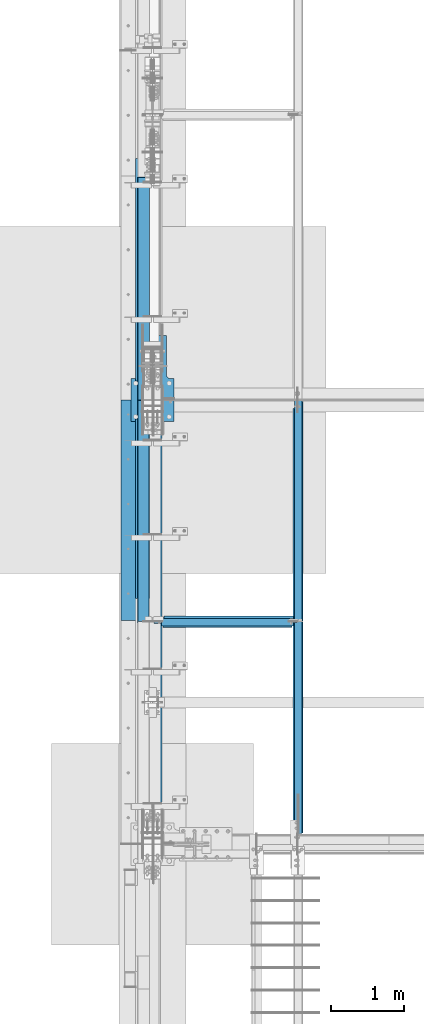
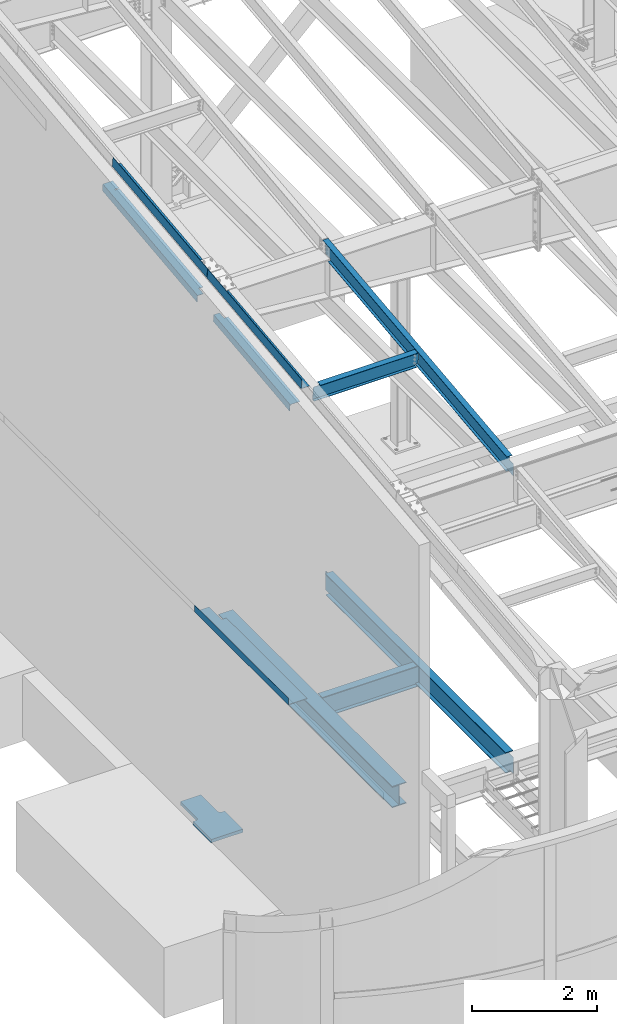
# One storey, part 707 of 1179: 11 beams, 8 elements without a shape of their own.
"""IFC2X3 building model written with IfcOpenShell, lengths in millimetres."""

import ifcopenshell
import ifcopenshell.guid

model = None  # the IFC model being written
_history = None  # IfcOwnerHistory: only IFC2X3 demands one
_inside = {}  # id of a spatial element -> (the spatial element, [elements in it])
_under = {}  # id of a project, library or spatial element -> (it, [spatial elements below it])
_declared = {}  # id of a project -> (the project, [libraries it declares])
_typed = {}  # id of a type object -> (the type object, [elements of that type])
_made_of = {}  # id of a material, layer set ... -> (it, [elements and type objects made of it])


def new_model(schema):
    """Start an empty IFC model of exactly this schema.

    Asked for "IFC4X3", IfcOpenShell would pick the latest addendum, in which some entities
    have other attributes; the version numbers below select the first issue.
    IFC2X3 requires an IfcOwnerHistory on every rooted entity: one is made here for all.
    """
    global model, _history
    if schema == "IFC4X3":
        model = ifcopenshell.file(schema_version=(4, 3, 0, 0))
    else:
        model = ifcopenshell.file(schema=schema)
    _inside.clear()
    _under.clear()
    _declared.clear()
    _typed.clear()
    _made_of.clear()
    _history = None
    if model.schema == "IFC2X3":
        org = make("IfcOrganization", Name="unknown")
        user = make(
            "IfcPersonAndOrganization",
            ThePerson=make("IfcPerson", FamilyName="unknown"),
            TheOrganization=org,
        )
        app = make(
            "IfcApplication",
            ApplicationDeveloper=org,
            Version="unknown",
            ApplicationFullName="unknown",
            ApplicationIdentifier="unknown",
        )
        _history = make(
            "IfcOwnerHistory",
            OwningUser=user,
            OwningApplication=app,
            ChangeAction="ADDED",
            CreationDate=0,
        )
    return model


def make(cls, **values):
    """One entity of the class cls with the attributes given. An attribute that is None is left unset."""
    return model.create_entity(
        cls, **{name: value for name, value in values.items() if value is not None}
    )


def rooted(cls, **values):
    """An entity with a GlobalId (a new one), such as an element, a storey or a relation."""
    return make(cls, GlobalId=ifcopenshell.guid.new(), OwnerHistory=_history, **values)


def si_unit(unit_type, name, prefix=None):
    """IfcSIUnit, for example si_unit("LENGTHUNIT", "METRE", prefix="MILLI")."""
    return make("IfcSIUnit", UnitType=unit_type, Prefix=prefix, Name=name)


def assignment(units):
    """IfcUnitAssignment: the units of a project."""
    return None if units is None else make("IfcUnitAssignment", Units=units)


def point(xyz):
    """IfcCartesianPoint."""
    return None if xyz is None else make("IfcCartesianPoint", Coordinates=xyz)


def direction(xyz):
    """IfcDirection."""
    return None if xyz is None else make("IfcDirection", DirectionRatios=xyz)


def frame(location, z_axis=None, x_axis=None):
    """IfcAxis2Placement3D, a coordinate frame: its origin and axes. An axis left out is left unset."""
    return make(
        "IfcAxis2Placement3D",
        Location=point(location),
        Axis=direction(z_axis),
        RefDirection=direction(x_axis),
    )


def origin_with_axes():
    """The frame at (0, 0, 0) with the z axis (0, 0, 1) and the x axis (1, 0, 0) written out."""
    return frame((0.0, 0.0, 0.0), z_axis=(0.0, 0.0, 1.0), x_axis=(1.0, 0.0, 0.0))


def place(relative_to, where):
    """IfcLocalPlacement: puts the frame where relative to a parent placement (None: the world)."""
    return make(
        "IfcLocalPlacement", PlacementRelTo=relative_to, RelativePlacement=where
    )


def context(
    kind, dimensions, precision=None, world=None, true_north=None, identifier=None
):
    """IfcGeometricRepresentationContext, for example the 3D "Model" context."""
    return make(
        "IfcGeometricRepresentationContext",
        ContextIdentifier=identifier,
        ContextType=kind,
        CoordinateSpaceDimension=dimensions,
        Precision=precision,
        WorldCoordinateSystem=world,
        TrueNorth=true_north,
    )


def subcontext(parent, identifier, kind, view, scale=None):
    """IfcGeometricRepresentationSubContext, for example "Body" below "Model"."""
    return make(
        "IfcGeometricRepresentationSubContext",
        ContextIdentifier=identifier,
        ContextType=kind,
        ParentContext=parent,
        TargetScale=scale,
        TargetView=view,
    )


def project(units=None, contexts=None):
    """IfcProject with its units and contexts."""
    return rooted(
        "IfcProject",
        Name="project",
        RepresentationContexts=contexts,
        UnitsInContext=assignment(units),
    )


def spatial(cls, under=None, at=None, **own):
    """A site, building, storey or space (cls), placed at a placement, below another one or the project."""
    s = rooted(cls, ObjectPlacement=at, **own)
    if under is not None:
        _under.setdefault(under.id(), (under, []))[1].append(s)
    return s


def faces_of(points, faces, orient=None, outer=None):
    """IfcFace entities. A face is a list of loops; a loop is a list of indices into points, from 0.

    orient and outer hold one flag for each loop. By default every Orientation is true, the
    first loop of a face is its IfcFaceOuterBound and the others are IfcFaceBound.
    """
    made = []
    for i, loops in enumerate(faces):
        bounds = []
        for j, loop in enumerate(loops):
            is_outer = j == 0 if outer is None else outer[i][j]
            bounds.append(
                make(
                    "IfcFaceOuterBound" if is_outer else "IfcFaceBound",
                    Bound=make("IfcPolyLoop", Polygon=[points[k] for k in loop]),
                    Orientation=True if orient is None else orient[i][j],
                )
            )
        made.append(make("IfcFace", Bounds=bounds))
    return made


def faceted_brep(points, faces, orient=None, outer=None, voids=None):
    """IfcFacetedBrep: a solid bounded by flat faces; with voids (closed shells), ...WithVoids."""
    shared = [point(p) for p in points]
    hull = make("IfcClosedShell", CfsFaces=faces_of(shared, faces, orient, outer))
    if voids is None:
        return make("IfcFacetedBrep", Outer=hull)
    return make(
        "IfcFacetedBrepWithVoids",
        Outer=hull,
        Voids=[
            make(cls, CfsFaces=faces_of(shared, fs, o, b)) for cls, fs, o, b in voids
        ],
    )


def shape(context_of_items, identifier, shape_type, items):
    """IfcShapeRepresentation: the items that make up one representation, for example the "Body"."""
    return make(
        "IfcShapeRepresentation",
        ContextOfItems=context_of_items,
        RepresentationIdentifier=identifier,
        RepresentationType=shape_type,
        Items=items,
    )


def material(Name=None, Category=None):
    """IfcMaterial."""
    return make("IfcMaterial", Name=Name, Category=Category)


def made_of(thing, what):
    """Note that an element or type object is made of a material, layer set ...; save() writes the relation."""
    if what is not None:
        _made_of.setdefault(what.id(), (what, []))[1].append(thing)
    return thing


def type_object(cls, material=None, **own):
    """A type object (cls), such as IfcWallType, which elements share."""
    return made_of(rooted(cls, **own), material)


def element(
    cls,
    number,
    at=None,
    inside=None,
    cuts=None,
    type_object=None,
    material=None,
    context=None,
    identifier="Body",
    shape_type=None,
    held_by="IfcProductDefinitionShape",
    body=None,
    shapes=None,
    **own,
):
    """One element of the class cls, such as IfcWall. Its Tag is "e" and its number.

    at: its placement. inside: the storey or other place that contains it. cuts: it is an
    opening in that element (IfcRelVoidsElement). A single representation is given by context,
    identifier, shape_type and body (its items); several are given by shapes. held_by: the class
    of the entity that holds the representations. save() writes the other relations.
    """
    e = rooted(cls, Tag="e%d" % number, ObjectPlacement=at, **own)
    if body is not None:
        shapes = [shape(context, identifier, shape_type, body)]
    if shapes is not None:
        e.Representation = make(held_by, Representations=shapes)
    if inside is not None:
        _inside.setdefault(inside.id(), (inside, []))[1].append(e)
    if cuts is not None:
        rooted(
            "IfcRelVoidsElement", RelatingBuildingElement=cuts, RelatedOpeningElement=e
        )
    if type_object is not None:
        _typed.setdefault(type_object.id(), (type_object, []))[1].append(e)
    return made_of(e, material)


def aggregate(whole, parts):
    """IfcRelAggregates: a whole, such as a stair, and the parts it consists of."""
    return rooted("IfcRelAggregates", RelatingObject=whole, RelatedObjects=parts)


def save(model, path):
    """Write the relations noted so far, then the file.

    IfcRelAggregates (storeys below a building ...), IfcRelContainedInSpatialStructure (elements
    in a storey), IfcRelDefinesByType, IfcRelAssociatesMaterial and IfcRelDeclares: one each for
    every whole, place, type object, material and project.
    """
    for whole, parts in _under.values():
        aggregate(whole, parts)
    for where, things in _inside.values():
        rooted(
            "IfcRelContainedInSpatialStructure",
            RelatedElements=things,
            RelatingStructure=where,
        )
    for kind, things in _typed.values():
        rooted("IfcRelDefinesByType", RelatedObjects=things, RelatingType=kind)
    for what, things in _made_of.values():
        rooted("IfcRelAssociatesMaterial", RelatedObjects=things, RelatingMaterial=what)
    for by, libraries in _declared.values():
        rooted("IfcRelDeclares", RelatingContext=by, RelatedDefinitions=libraries)
    model.write(path)


model = new_model("IFC2X3")

# Units and contexts
model_context = context("Model", 3, precision=1e-05, world=origin_with_axes())
body_context = subcontext(model_context, "Body", "Model", "MODEL_VIEW")
ifc_project = project(units=[si_unit("LENGTHUNIT", "METRE", prefix="MILLI"), si_unit("AREAUNIT", "SQUARE_METRE"), si_unit("VOLUMEUNIT", "CUBIC_METRE"), si_unit("MASSUNIT", "GRAM", prefix="KILO"), si_unit("TIMEUNIT", "SECOND"), si_unit("PLANEANGLEUNIT", "RADIAN"), si_unit("SOLIDANGLEUNIT", "STERADIAN"), si_unit("THERMODYNAMICTEMPERATUREUNIT", "DEGREE_CELSIUS"), si_unit("LUMINOUSINTENSITYUNIT", "LUMEN")], contexts=[model_context])

# Site, building, storey
site_placement = place(None, origin_with_axes())
site = spatial("IfcSite", under=ifc_project, at=site_placement, CompositionType="ELEMENT")
building_placement = place(site_placement, origin_with_axes())
building = spatial("IfcBuilding", under=site, at=building_placement, Name="Undefined", CompositionType="ELEMENT")
storey_placement = place(building_placement, origin_with_axes())
storey = spatial("IfcBuildingStorey", under=building, at=storey_placement, Name="Undefined", CompositionType="ELEMENT", Elevation=0.0)

# Assembly, beam
assembly_1_placement = place(storey_placement, origin_with_axes())
assembly_1 = element("IfcElementAssembly", 1, at=assembly_1_placement, inside=storey, Name="BEAM", AssemblyPlace="NOTDEFINED", PredefinedType="RIGID_FRAME")
ifc_material_1 = material(Name="STEEL/A992")
beam_type_1 = type_object("IfcBeamType", Name="W12X14", PredefinedType="NOTDEFINED")
beam_1_placement = place(assembly_1_placement, frame((431.800079778882, 8475.15251394604, 10052.7877808975), z_axis=(0.0, -0.112284087038017, 0.993676146336441), x_axis=(0.999999999988899, -4.71199999952473e-06, 0.0)))
beam_1 = element("IfcBeam", 2, at=beam_1_placement, type_object=beam_type_1, material=ifc_material_1, Name="BEAM", ObjectType="W12X14", context=body_context, shape_type="Brep", body=[
    faceted_brep([(108.743508988838, -2.38124999987667, 112.712499998228), (108.743508988841, 2.38187199516506, 112.712499998232), (19.8437187060635, 2.38125000005857, 112.712499998292), (19.8437410050471, -2.38124999993852, 112.712499998293), (113.603588506884, -2.3812499998694, 113.679229920812), (113.603588506887, 2.38187942188961, 113.679229920817), (117.723764975037, -2.3812499998694, 116.432243821288), (117.72376497504, 2.38190057140491, 116.432243821291), (120.476778875514, -2.38124999986394, 120.552420289438), (120.476778875518, 2.38193222389054, 120.552420289439), (121.443508798101, -2.38124999986212, 125.412499807475), (121.443508798105, 2.3819695605398, 125.412499807479), (121.443508798216, -50.799999999841, 150.812499999922), (121.443508798143, 50.8000000001357, 150.812499999936), (121.443508798143, 50.8000000001321, 144.462499999936), (121.443508798178, 2.38125000014588, 144.462499999929), (121.443508798181, -2.38124999985303, 144.462499999931), (121.443508798216, -50.7999999998428, 144.462499999923), (1918.49398789085, 50.8000000012998, -144.462500000085), (1918.49398789085, 50.8000000012962, -150.812500000084), (159.543341447114, 50.8000000000393, -150.812499999942), (159.543344806789, 50.8000000000429, -144.462499999943), (19.8436049382477, -2.38125000004402, -144.46249999994), (19.8438316445805, -50.800000000032, -144.462499999947), (1918.49398789092, -50.7999999986769, -144.4625000001), (1918.49398789089, -2.38124999868705, -144.462500000092), (19.8438282849064, -50.8000000000338, -150.812499999945), (1918.49398789092, -50.7999999986787, -150.812500000098), (19.8435793038935, 2.37605939286368, -150.812499999936), (159.543568174748, 2.37671349638731, -150.812499999947), (159.543571534422, 2.37671349640914, -144.462499999952), (19.8435826392642, 2.38124999995489, -144.462499999941), (1918.49398789088, 2.38125000131004, -144.462500000094), (1918.49398789097, 2.38125000131367, -138.112499809924), (1918.49398789096, -2.38124999868705, -138.112499809926), (1919.46071781356, 2.38125000131367, -133.252420291883), (1919.46071781355, -2.38124999868342, -133.252420291885), (1922.21373171403, 2.38125000131913, -129.132243823735), (1922.21373171403, -2.38124999867796, -129.132243823738), (1926.33390818219, 2.38125000132277, -126.379229923261), (1926.33390818219, -2.3812499986725, -126.379229923265), (1931.19398770024, 2.38125000132823, -125.412500000673), (1931.19398770023, -2.3812499986725, -125.412500000679), (1966.11861503894, -2.38124999864704, -125.412500000759), (1966.11859273996, 2.38125000135369, -125.412500000761), (1966.11872544708, 2.38125000145374, 125.41249999894), (1966.11874774607, -2.38124999854517, 125.41249999894), (1931.19398770021, 2.38125000143009, 125.412499999011), (1931.1939877002, -2.38124999856882, 125.412499999005), (1926.33390818216, 2.38125000142645, 126.379229921597), (1926.33390818216, -2.38124999857246, 126.379229921593), (1922.21373171401, 2.38125000142463, 129.132243822072), (1922.213731714, -2.3812499985761, 129.132243822069), (1919.46071781353, 2.38125000142463, 133.25242029022), (1919.46071781352, -2.38124999857428, 133.252420290219), (1918.49398789094, 2.38125000142645, 138.112499808261), (1918.49398789094, -2.38124999857428, 138.112499808256), (1918.49398789089, -50.7999999985568, 150.812499999776), (1918.49398789089, -50.7999999985605, 144.462499999778), (1918.49398789085, -2.38124999857064, 144.462499999785), (1918.49398789085, 2.38125000142645, 144.462499999785), (1918.49398789081, 50.8000000014163, 144.462499999792), (1918.49398789081, 50.8000000014199, 150.812499999791)], [[[0, 1, 2, 3]], [[4, 5, 1, 0]], [[6, 7, 5, 4]], [[8, 9, 7, 6]], [[10, 11, 9, 8]], [[12, 13, 14, 15, 11, 10, 16, 17]], [[18, 19, 20, 21]], [[22, 23, 24, 25]], [[23, 26, 27, 24]], [[19, 27, 26, 28, 29, 20]], [[30, 29, 28, 31]], [[21, 20, 29, 30]], [[32, 18, 21, 30]], [[25, 24, 27, 19, 18, 32, 33, 34]], [[34, 33, 35, 36]], [[36, 35, 37, 38]], [[38, 37, 39, 40]], [[40, 39, 41, 42]], [[43, 42, 41, 44]], [[45, 46, 43, 44]], [[46, 45, 47, 48]], [[48, 47, 49, 50]], [[50, 49, 51, 52]], [[52, 51, 53, 54]], [[54, 53, 55, 56]], [[57, 58, 59, 56, 55, 60, 61, 62]], [[58, 57, 12, 17]], [[59, 58, 17, 16]], [[8, 6, 4, 0, 3, 22, 25, 34, 36, 38, 40, 42, 43, 46, 48, 50, 52, 54, 56, 59, 16, 10]], [[31, 28, 26, 23, 22, 3, 2]], [[60, 55, 53, 51, 49, 47, 45, 44, 41, 39, 37, 35, 33, 32, 30, 31, 2, 1, 5, 7, 9, 11, 15]], [[61, 60, 15, 14]], [[62, 61, 14, 13]], [[57, 62, 13, 12]]]),
])
aggregate(assembly_1, [beam_1])

assembly_2_placement = place(storey_placement, origin_with_axes())
assembly_2 = element("IfcElementAssembly", 3, at=assembly_2_placement, inside=storey, Name="BEAM", AssemblyPlace="NOTDEFINED", PredefinedType="RIGID_FRAME")
beam_2_placement = place(assembly_2_placement, frame((2413.0, 5452.5431792468, 9711.23798851528), z_axis=(0.0, -0.112284087038017, 0.993676146336441), x_axis=(0.0, 0.993676146336441, 0.112284087038017)))
beam_2 = element("IfcBeam", 4, at=beam_2_placement, type_object=beam_type_1, material=ifc_material_1, Name="BEAM", ObjectType="W12X14", context=body_context, shape_type="Brep", body=[
    faceted_brep([(-14.2318769662725, -2.38124999999991, -144.462499999929), (-14.9494185450649, -2.38115214303389, -150.812499999924), (137.488001223044, -2.38117577009325, -150.8125), (137.488001223013, -2.38125000000036, -144.462500000003), (137.48799371822, -50.7999999999993, -144.462500000005), (137.487993718216, -50.7999999999993, -150.812500000002), (5871.37503272929, 50.7999999999993, -144.462500002917), (5870.65749114864, 50.7999999999993, -150.812500002912), (137.488009517103, 50.7999999999993, -150.812500000002), (137.488009517107, 50.7999999999993, -144.462500000003), (137.488002012233, 2.3811758245356, -144.462500001737), (137.488002012265, 2.38132415558357, -150.812500000002), (-14.949328679897, 2.38134778320455, -150.812499999924), (-14.2317871011028, 2.38124999999991, -144.462499999927), (5871.37503272928, 2.38124783346939, -144.462500002968), (6076.55490468175, 2.38124999999854, 144.462499996846), (6076.55490468175, 50.7999999999993, 144.462499996846), (6077.27244626239, 50.7999999999993, 150.812499996842), (6077.27244626239, -50.7999999999993, 150.812499996842), (6076.55490468175, -50.7999999999993, 144.462499996846), (6076.55490468175, -2.38124999999854, 144.462499996846), (6045.98095926941, -2.38124999999854, -126.106563095373), (6045.98095929506, 2.38124999999854, -126.10656309827), (5888.24414721426, -2.38124999999854, -108.282512497075), (5888.24414721426, 2.38122772319184, -108.282512497075), (5883.30625374162, -2.38124999999854, -108.697419370077), (5883.30625374162, 2.38122766974266, -108.697419370077), (5878.90301301472, -2.38124999999854, -110.970393360541), (5878.90301301472, 2.38122737693629, -110.970393360541), (5875.70477851863, -2.38124999999854, -114.755394783042), (5875.70477851863, 2.38122688934163, -114.755394783042), (5874.19845246322, -2.38124999999854, -119.476191482236), (5874.19845246322, 2.38122628119891, -119.476191482236), (5871.37503272929, -2.38124999999854, -144.462500002917), (5871.37503272929, -50.7999999999993, -144.462500002917), (5870.65749114864, -50.7999999999993, -150.812500002912), (-13.966470462532, -2.38124999999991, -142.113742319232), (12.1694588939627, -2.38124999999991, 89.1803818007484), (12.1695476261366, 2.38124999999991, 89.1803717741295), (-13.9663680209596, 2.38124999999991, -142.113631022323), (125.78359955719, -2.38125000000036, 76.342134544826), (125.78359955719, 2.38125000000036, 76.342134544826), (130.721493030343, -2.38125000000036, 76.7570414172296), (130.721493030343, 2.38125000000036, 76.7570414172296), (135.124733757862, -2.38125000000036, 79.0300154074976), (135.124733757862, 2.38125000000036, 79.0300154074976), (138.322968254461, -2.38125000000036, 82.8150168301745), (138.322968254461, 2.38125000000036, 82.8150168301745), (139.829294310099, -2.38125000000036, 87.5358135297793), (139.829294310099, 2.38125000000036, 87.5358135297793), (146.26193440305, 2.38125000000036, 144.46249999986), (146.26193440305, 50.7999999999993, 144.46249999986), (146.979475983694, 50.7999999999993, 150.812499999854), (146.979475983694, -50.7999999999993, 150.812499999854), (146.26193440305, -50.7999999999993, 144.46249999986), (146.26193440305, -2.38125000000036, 144.46249999986)], [[[0, 1, 2, 3]], [[4, 3, 2, 5]], [[6, 7, 8, 9]], [[10, 11, 12, 13]], [[9, 8, 11, 10]], [[14, 6, 9, 10]], [[15, 16, 17, 18, 19, 20, 21, 22]], [[21, 23, 24, 22]], [[25, 26, 24, 23]], [[27, 28, 26, 25]], [[29, 30, 28, 27]], [[31, 32, 30, 29]], [[33, 34, 35, 7, 6, 14, 32, 31]], [[35, 34, 4, 5]], [[1, 12, 11, 8, 7, 35, 5, 2]], [[36, 37, 38, 39, 13, 12, 1, 0]], [[40, 41, 38, 37]], [[42, 43, 41, 40]], [[44, 45, 43, 42]], [[46, 47, 45, 44]], [[48, 49, 47, 46]], [[15, 22, 24, 26, 28, 30, 32, 14, 10, 13, 39, 38, 41, 43, 45, 47, 49, 50]], [[16, 15, 50, 51]], [[17, 16, 51, 52]], [[18, 17, 52, 53]], [[19, 18, 53, 54]], [[20, 19, 54, 55]], [[53, 52, 51, 50, 49, 48, 55, 54]], [[46, 44, 42, 40, 37, 36, 0, 3, 33, 31, 29, 27, 25, 23, 21, 20, 55, 48]], [[34, 33, 3, 4]]]),
])
aggregate(assembly_2, [beam_2])

assembly_3_placement = place(storey_placement, origin_with_axes())
assembly_3 = element("IfcElementAssembly", 5, at=assembly_3_placement, inside=storey, Name="BEAM", AssemblyPlace="NOTDEFINED", PredefinedType="RIGID_FRAME")
beam_type_2 = type_object("IfcBeamType", Name="W16X31", PredefinedType="NOTDEFINED")
beam_3_placement = place(assembly_3_placement, frame((431.799998504718, 8458.19987963044, 3900.4875), z_axis=(0.0, 0.0, 1.0), x_axis=(1.0, 0.0, 0.0)))
beam_3 = element("IfcBeam", 6, at=beam_3_placement, type_object=beam_type_2, material=ifc_material_1, Name="BEAM", ObjectType="W16X31", context=body_context, shape_type="Brep", body=[
    faceted_brep([(143.668751495283, -69.8500000000004, -190.5), (143.668751495283, -69.8500000000004, -201.6125), (1898.6499306287, -69.8500000000004, -201.6125), (1898.6499306287, -69.8500000000004, -190.5), (143.668751495283, 69.8500000000004, -201.6125), (1898.6499306287, 69.8500000000004, -201.6125), (143.668751495283, 69.8500000000004, -190.5), (1898.6499306287, 69.8500000000004, -190.5), (143.668751495283, 3.17549009286085, -190.5), (1898.6499306287, 3.17501793803967, -190.5), (1965.32492902848, -3.17499999999927, -169.862499999999), (1965.32492887608, 3.17499999999927, -169.862499999999), (1965.32492887608, 3.17499999999927, 169.862500000001), (1965.32492902848, -3.17499999999927, 169.862500000001), (1911.34993043796, -3.17499999999927, -169.862499999999), (1911.34993043796, 3.17517188729289, -169.862499999999), (1906.48985091992, -3.17499999999927, -170.829229922587), (1906.48985091992, 3.17517252465404, -170.829229922587), (1902.36967445176, -3.17499999999927, -173.582243823065), (1902.36967445176, 3.17517427671919, -173.582243823065), (1899.61666055128, -3.17499999999927, -177.702420291219), (1899.61666055128, 3.17517687675354, -177.702420291219), (1898.6499306287, -3.17499999999927, -182.562499809264), (1898.6499306287, 3.17517992892135, -182.562499809264), (1898.6499306287, -3.17499999999927, -190.5), (143.668751495283, -3.17499999999927, -190.5), (143.668751495283, -3.17499999999927, -182.562499809265), (143.668751495283, 3.17520391602375, -182.562499809265), (142.702021572695, -3.17499999999927, -177.702420291219), (142.702021572695, 3.17520070397586, -177.702420291219), (139.949007672217, -3.17499999999927, -173.582243823066), (139.949007672217, 3.17519797957902, -173.582243823066), (135.828831204064, -3.17499999999927, -170.829229922588), (135.828831204064, 3.17519615760284, -170.829229922588), (130.968751686018, -3.17499999999927, -169.8625), (130.968751686018, 3.175195515425, -169.8625), (18.2562514952835, -3.17499999999927, -169.8625), (18.2562514952835, 3.17499999999927, -169.8625), (18.2562514952835, -3.17499999999927, 169.8625), (18.2562514952835, 3.17499999999927, 169.8625), (130.968751686018, -3.17499999999927, 169.8625), (130.968751686018, 3.17497419032952, 169.8625), (135.828831204064, -3.17499999999927, 170.829229922588), (135.828831204064, 3.17497355392152, 170.829229922588), (139.949007672217, -3.17499999999927, 173.582243823066), (139.949007672217, 3.17497173859556, 173.582243823066), (142.702021572695, -3.17499999999927, 177.70242029122), (142.702021572695, 3.1749690207198, 177.70242029122), (143.668751495283, -3.17499999999927, 182.562499809265), (143.668751495283, 3.17496581406522, 182.562499809265), (143.668751495283, -69.8500000000004, 201.6125), (143.668751495283, 69.8500000000004, 201.6125), (143.668751495283, 69.8500000000004, 190.5), (143.668751495283, 3.17499999999927, 190.5), (143.668751495283, -3.17499999999927, 190.5), (143.668751495283, -69.8500000000004, 190.5), (1898.6499306287, 69.8500000000004, 190.5), (1898.6499306287, 3.17499999999927, 190.5), (1898.6499306287, 3.17495466839318, 182.562499809266), (1899.61666055128, 3.17495775882526, 177.70242029122), (1902.36967445176, 3.17496037415549, 173.582243823067), (1906.48985091992, 3.17496211621983, 170.829229922589), (1911.34993043796, 3.17496271980963, 169.862500000001), (1899.61666055128, -3.17499999999927, 177.70242029122), (1898.6499306287, -3.17499999999927, 182.562499809266), (1902.36967445176, -3.17499999999927, 173.582243823067), (1906.48985091992, -3.17499999999927, 170.829229922589), (1911.34993043796, -3.17499999999927, 169.862500000001), (1898.6499306287, -3.17499999999927, 190.5), (1898.6499306287, -69.8500000000004, 190.5), (1898.6499306287, -69.8500000000004, 201.6125), (1898.6499306287, 69.8500000000004, 201.6125)], [[[0, 1, 2, 3]], [[1, 4, 5, 2]], [[4, 6, 7, 5]], [[6, 8, 9, 7]], [[10, 11, 12, 13]], [[10, 14, 15, 11]], [[16, 17, 15, 14]], [[18, 19, 17, 16]], [[20, 21, 19, 18]], [[22, 23, 21, 20]], [[24, 3, 2, 5, 7, 9, 23, 22]], [[25, 0, 3, 24]], [[26, 27, 8, 6, 4, 1, 0, 25]], [[28, 29, 27, 26]], [[30, 31, 29, 28]], [[32, 33, 31, 30]], [[34, 35, 33, 32]], [[36, 37, 35, 34]], [[38, 39, 37, 36]], [[40, 41, 39, 38]], [[42, 43, 41, 40]], [[44, 45, 43, 42]], [[46, 47, 45, 44]], [[48, 49, 47, 46]], [[50, 51, 52, 53, 49, 48, 54, 55]], [[53, 52, 56, 57]], [[11, 15, 17, 19, 21, 23, 9, 8, 27, 29, 31, 33, 35, 37, 39, 41, 43, 45, 47, 49, 53, 57, 58, 59, 60, 61, 62, 12]], [[63, 59, 58, 64]], [[65, 60, 59, 63]], [[66, 61, 60, 65]], [[67, 62, 61, 66]], [[13, 12, 62, 67]], [[66, 65, 63, 64, 68, 54, 48, 46, 44, 42, 40, 38, 36, 34, 32, 30, 28, 26, 25, 24, 22, 20, 18, 16, 14, 10, 13, 67]], [[55, 54, 68, 69]], [[50, 55, 69, 70]], [[51, 50, 70, 71]], [[52, 51, 71, 56]], [[70, 69, 68, 64, 58, 57, 56, 71]]]),
])
aggregate(assembly_3, [beam_3])

assembly_4_placement = place(storey_placement, origin_with_axes())
assembly_4 = element("IfcElementAssembly", 7, at=assembly_4_placement, inside=storey, Name="BEAM", AssemblyPlace="NOTDEFINED", PredefinedType="RIGID_FRAME")
beam_4_placement = place(assembly_4_placement, frame((2413.0, 5435.6, 3900.4875), z_axis=(0.0, 0.0, 1.0), x_axis=(0.0, 1.0, 0.0)))
beam_4 = element("IfcBeam", 8, at=beam_4_placement, type_object=beam_type_2, material=ifc_material_1, Name="BEAM", ObjectType="W16X31", context=body_context, shape_type="Brep", body=[
    faceted_brep([(19.0499999238054, -3.17500000000564, -147.6375), (19.0500000762049, 3.17499999999382, -147.6375), (141.287498514381, 3.17519843052196, -147.6375), (141.28749851438, -3.17500000003656, -147.6375), (146.147578032426, 3.17519914073091, -148.604229922588), (146.147578032425, -3.17500000003838, -148.604229922588), (150.26775450058, 3.175201160494, -151.357243823066), (150.267754500579, -3.17500000003838, -151.357243823066), (153.020768401058, 3.17520418232016, -155.47742029122), (153.020768401057, -3.1750000000402, -155.47742029122), (153.987498323645, -3.1750000000402, -160.337499809265), (153.987498323647, 3.17520774616514, -160.337499809265), (153.988000076218, 3.17556876199342, -190.5), (153.988000076218, 3.17556876199342, -201.6125), (153.987498323628, -69.8500000000395, -201.6125), (153.987498323628, -69.8500000000395, -190.5), (153.987498323645, -3.1750000000402, -190.5), (5900.73750167641, 69.8499999985015, -190.5), (5900.73750167641, 69.8499999985015, -201.6125), (153.988001676405, 69.8499999999603, -201.6125), (153.988001676405, 69.8499999999603, -190.5), (5900.73750007622, 3.17499999850133, -190.5), (5900.73750007622, 3.17542779204359, -201.6125), (6027.73750007621, 3.17499999846859, -190.5), (6027.73750007622, 3.17542474404308, -201.6125), (5927.72500167648, 69.8499999984942, 190.5), (5927.72500167647, 3.17499999849406, 190.5), (153.987498323646, 3.17499999996016, 190.5), (153.987498323663, 69.8499999999603, 190.5), (141.28749851438, -3.17500000003656, 169.8625), (141.287498514381, 3.17496707379814, 169.8625), (19.0500000762049, 3.17499999999382, 169.8625), (19.0499999238054, -3.17500000000564, 169.8625), (146.147578032425, -3.17500000003838, 170.829229922588), (146.147578032426, 3.17496636684882, 170.829229922588), (150.267754500579, -3.17500000003838, 173.582243823066), (150.26775450058, 3.17496435362955, 173.582243823066), (153.020768401057, -3.1750000000402, 177.702420291219), (153.020768401058, 3.17496134063458, 177.702420291219), (153.987498323645, -3.1750000000402, 182.562499809265), (153.987498323646, 3.17495778656485, 182.562499809265), (5927.72500167645, -69.8500000015056, 201.6125), (5927.72500167648, 69.8499999984942, 201.6125), (153.987498323663, 69.8499999999603, 201.6125), (153.987498323628, -69.8500000000395, 201.6125), (5927.72500167645, -69.8500000015056, 190.5), (153.987498323628, -69.8500000000395, 190.5), (5927.72500167647, -3.1750000015054, 190.5), (153.987498323645, -3.1750000000402, 190.5), (5927.72500167647, -3.1750000015054, 182.562499809265), (5927.72500167647, 3.17499999849406, 182.562499809265), (5928.69173159905, -3.1750000015054, 177.702420291219), (5928.69173159905, 3.17499999849406, 177.702420291219), (5931.44474549953, -3.17500000150721, 173.582243823066), (5931.44474549953, 3.17499999849315, 173.582243823066), (5935.56492196769, -3.17500000150812, 170.829229922588), (5935.56492196769, 3.17499999849224, 170.829229922588), (5940.42500148573, -3.17500000150903, 169.8625), (5940.42500148573, 3.17499999849133, 169.8625), (6027.73749992381, -3.17500000153177, 169.8625), (6027.73750007621, 3.17499999846859, 169.8625), (6027.73749992381, -3.17500000153177, -190.5), (6027.73749832361, -69.850000001531, -190.5), (6027.73749832361, -69.850000001531, -201.6125)], [[[0, 1, 2, 3]], [[3, 2, 4, 5]], [[5, 4, 6, 7]], [[7, 6, 8, 9]], [[10, 11, 12, 13, 14, 15, 16]], [[9, 8, 11, 10]], [[17, 18, 19, 20]], [[21, 22, 18, 17]], [[23, 24, 22, 21]], [[25, 26, 27, 28]], [[29, 30, 31, 32]], [[33, 34, 30, 29]], [[35, 36, 34, 33]], [[37, 38, 36, 35]], [[39, 40, 38, 37]], [[41, 42, 43, 44]], [[45, 41, 44, 46]], [[47, 45, 46, 48]], [[44, 43, 28, 27, 40, 39, 48, 46]], [[42, 25, 28, 43]], [[41, 45, 47, 49, 50, 26, 25, 42]], [[51, 52, 50, 49]], [[53, 54, 52, 51]], [[55, 56, 54, 53]], [[57, 58, 56, 55]], [[59, 60, 58, 57]], [[61, 62, 63, 24, 23, 60, 59]], [[62, 61, 16, 15]], [[63, 62, 15, 14]], [[19, 18, 22, 24, 63, 14, 13]], [[20, 19, 13, 12]], [[21, 17, 20, 12]], [[6, 4, 2, 1, 31, 30, 34, 36, 38, 40, 27, 26, 50, 52, 54, 56, 58, 60, 23, 21, 12, 11, 8]], [[32, 31, 1, 0]], [[61, 59, 57, 55, 53, 51, 49, 47, 48, 39, 37, 35, 33, 29, 32, 0, 3, 5, 7, 9, 10, 16]]]),
])
aggregate(assembly_4, [beam_4])

assembly_5_placement = place(storey_placement, origin_with_axes())
assembly_5 = element("IfcElementAssembly", 9, at=assembly_5_placement, inside=storey, Name="BEAM", AssemblyPlace="NOTDEFINED", PredefinedType="RIGID_FRAME")
ifc_material_2 = material(Name="STEEL/A36")
beam_type_3 = type_object("IfcBeamType", PredefinedType="NOTDEFINED")
beam_5_placement = place(assembly_5_placement, frame((388.937000000002, 12997.8759537224, 10718.8180795381), z_axis=(0.0, -0.993676146336441, -0.112284087038017), x_axis=(-1.0, 0.0, 0.0)))
beam_5 = element("IfcBeam", 10, at=beam_5_placement, type_object=beam_type_3, material=ifc_material_2, Name="BENT_PLATE", context=body_context, shape_type="Brep", body=[
    faceted_brep([(71.4368785873797, -3.17500000044674, 1106.32825735563), (71.4369127138908, 3.1552416220693, 1106.32795962198), (0.0, 3.17499999954998, 1106.32798145128), (0.0, -3.17500000044674, 1106.32827920303), (71.4369393073932, -3.17499997037885, 1524.00064289679), (71.4369735398088, 3.174999999379, 1523.99999999915), (153.98700000004, -3.17499999938263, -1523.99999999915), (0.0, -3.17499999999927, -1524.0), (0.0, 3.17499999999927, -1524.0), (160.33700000004, 3.17500000061409, -1523.99999999915), (160.337000000008, -187.324999998866, -1523.99999999923), (153.987000000008, -187.324999998866, -1523.99999999923), (160.336999999976, 3.174999999379, 1523.99999999915), (160.337000000008, -187.325000000099, 1523.99999999907), (153.987000000008, -187.325000000099, 1523.99999999907), (153.986999999976, -3.17500000061773, 1523.99999999914)], [[[0, 1, 2, 3]], [[4, 5, 1, 0]], [[6, 7, 8, 9, 10, 11]], [[9, 12, 13, 10]], [[14, 11, 10, 13]], [[15, 6, 11, 14]], [[3, 7, 6, 15, 4, 0]], [[8, 7, 3, 2]], [[12, 9, 8, 2, 1, 5]], [[15, 14, 13, 12, 5, 4]]]),
])

# Assembly, beams
assembly_6_placement = place(storey_placement, origin_with_axes())
assembly_6 = element("IfcElementAssembly", 11, at=assembly_6_placement, inside=storey, Name="BEAM", AssemblyPlace="NOTDEFINED", PredefinedType="RIGID_FRAME")
beam_type_4 = type_object("IfcBeamType", PredefinedType="NOTDEFINED")
beam_6_placement = place(assembly_6_placement, frame((382.587000106462, 9972.07873969633, 10376.907006187), z_axis=(0.0, -0.993676146336441, -0.112284087038017), x_axis=(-1.0, 0.0, 0.0)))
beam_6 = element("IfcBeam", 12, at=beam_6_placement, type_object=beam_type_4, material=ifc_material_2, Name="BENT_PLATE", context=body_context, shape_type="Brep", body=[
    faceted_brep([(65.0868016130075, -3.17499999955362, -1098.78874971484), (65.0868357282832, 3.15034127701438, -1098.78874697107), (65.0867263555347, 3.17500000061045, -1514.47499999915), (65.0866922390257, -3.17499999938627, -1514.47499999915), (6.65068000671454e-12, -3.17499999955544, -1098.7887284536), (6.65068000671454e-12, 3.17500000044311, -1098.78872570966), (153.986999969978, 3.17499999938263, 1514.47499999915), (-9.15179043659009e-12, 3.17499999938263, 1514.47499999915), (-9.15179043659009e-12, -3.17500000061409, 1514.47499999915), (147.636999969978, -3.17500000061409, 1514.47499999915), (147.636999969995, -187.325000029692, 1514.47499999908), (153.986999969995, -187.325000029692, 1514.47499999908), (153.986999970011, 3.17500000061045, -1514.47499999915), (153.986999969995, -187.325000028466, -1514.47499999923), (147.636999969995, -187.325000028466, -1514.47499999923), (147.636999970011, -3.17499999938627, -1514.47499999915)], [[[0, 1, 2, 3]], [[4, 5, 1, 0]], [[6, 7, 8, 9, 10, 11]], [[12, 6, 11, 13]], [[10, 14, 13, 11]], [[9, 15, 14, 10]], [[12, 13, 14, 15, 3, 2]], [[7, 6, 12, 2, 1, 5]], [[8, 7, 5, 4]], [[15, 9, 8, 4, 0, 3]]]),
])
beam_type_5 = type_object("IfcBeamType", PredefinedType="NOTDEFINED")
beam_7_placement = place(assembly_6_placement, frame((388.937000109975, 10001.108556615, 9851.38074222301), z_axis=(0.0, -0.993676146336441, -0.112284087038017), x_axis=(-1.0, 0.0, 0.0)))
beam_7 = element("IfcBeam", 13, at=beam_7_placement, type_object=beam_type_5, material=ifc_material_2, Name="BENT_PLATE", context=body_context, shape_type="Brep", body=[
    faceted_brep([(76.1995001093853, -3.17449425665836, -1082.6750000144), (76.1995001093853, 3.17611935709101, -1082.67500001688), (76.1995001093853, 3.17500000050131, -1228.72499999931), (76.1995001093853, -3.17499999949541, -1228.72499999931), (5.62749846721999e-12, -3.1749999995609, -1082.6750000144), (5.17275111633353e-12, 3.17500000043765, -1082.67500001688), (179.387000109414, 3.17499999951178, 1228.72499999931), (-6.3664629124105e-12, 3.17499999949905, 1228.72499999931), (-5.91171556152403e-12, -3.17500000049586, 1228.72499999931), (185.737000109414, -3.17500000048312, 1228.72499999931), (185.73700010943, 136.524999886711, 1228.72499999937), (179.38700010943, 136.524999886711, 1228.72499999937), (179.387000109443, 3.17500000050859, -1228.72499999931), (179.38700010943, 136.524999887706, -1228.72499999926), (185.73700010943, 136.524999887706, -1228.72499999926), (185.737000109443, -3.17499999948814, -1228.72499999931)], [[[0, 1, 2, 3]], [[4, 5, 1, 0]], [[6, 7, 8, 9, 10, 11]], [[12, 6, 11, 13]], [[10, 14, 13, 11]], [[9, 15, 14, 10]], [[12, 13, 14, 15, 3, 2]], [[7, 6, 12, 2, 1, 5]], [[8, 7, 5, 4]], [[15, 9, 8, 4, 0, 3]]]),
])
aggregate(assembly_6, [beam_6, beam_7])

# Beam
beam_8_placement = place(assembly_5_placement, frame((388.937000226156, 13255.868948985, 10219.1643500493), z_axis=(0.0, -0.993676146336441, -0.112284087038017), x_axis=(-1.0, 0.0, 0.0)))
beam_8 = element("IfcBeam", 14, at=beam_8_placement, type_object=beam_type_5, material=ifc_material_2, Name="BENT_PLATE", context=body_context, shape_type="Brep", body=[
    faceted_brep([(76.1995002256737, -3.17561432592629, -1324.9384575608), (76.1995002256737, 3.17499928789402, -1324.93845756081), (-6.76436684443615e-12, 3.17500000053587, -1324.9384575608), (-6.42330633127131e-12, -3.17499999946085, -1324.9384575608), (76.1995002256737, -3.17561432593175, -1309.06345756099), (76.1995002256737, 3.17499928788675, -1309.06345756097), (-6.3664629124105e-12, -3.17499999946813, -1309.06345756099), (-6.65068000671454e-12, 3.17500000052678, -1309.06345756097), (185.737000203274, -3.17500000222026, 1523.9999999998), (185.737000201926, -3.17500000083055, -1523.99999999987), (185.73700022686, 136.524387941527, -1523.99999999909), (185.73700022686, 136.52438794029, 1523.9999999992), (76.1995001797359, -3.17550574784764, 1377.95000001703), (76.1995001797359, 3.17510786590537, 1377.95000001449), (7.27595761418343e-12, 3.17500000055588, 1377.94999996396), (7.27595761418343e-12, -3.1749999994372, 1377.94999996142), (76.1995001797359, -3.1750000051652, 1524.00000000082), (76.1995002269396, 3.17500000061045, 1523.99999999914), (179.387000226859, 136.52438794029, 1523.9999999992), (179.387000203274, 3.1749999978274, 1523.9999999998), (179.387000201926, 3.17499999921893, -1523.99999999987), (179.387000226859, 136.524387941527, -1523.99999999909), (0.0, -3.17499999999927, -1524.0), (0.0, 3.17499999999927, -1524.0)], [[[0, 1, 2, 3]], [[4, 5, 1, 0]], [[6, 7, 5, 4]], [[8, 9, 10, 11]], [[12, 13, 14, 15]], [[16, 17, 13, 12]], [[8, 11, 18, 19, 17, 16]], [[20, 19, 18, 21]], [[11, 10, 21, 18]], [[9, 22, 23, 20, 21, 10]], [[23, 22, 3, 2]], [[14, 13, 17, 19, 20, 23, 2, 1, 5, 7]], [[15, 14, 7, 6]], [[3, 22, 9, 8, 16, 12, 15, 6, 4, 0]]]),
])

aggregate(assembly_5, [beam_5, beam_8])

# Assembly, beams
assembly_7_placement = place(storey_placement, origin_with_axes())
assembly_7 = element("IfcElementAssembly", 15, at=assembly_7_placement, inside=storey, Name="BEAM", AssemblyPlace="NOTDEFINED", PredefinedType="RIGID_FRAME")
beam_type_6 = type_object("IfcBeamType", PredefinedType="NOTDEFINED")
beam_9_placement = place(assembly_7_placement, frame((352.4255, 9980.61200275072, 4105.275), z_axis=(0.0, -1.0, 0.0), x_axis=(-1.0, 0.0, 0.0)))
beam_9 = element("IfcBeam", 16, at=beam_9_placement, type_object=beam_type_6, material=ifc_material_2, Name="BENT_PLATE", context=body_context, shape_type="Brep", body=[
    faceted_brep([(84.1380004882872, -3.17500000000018, -1093.78798828125), (84.1380004882872, 3.17500000000018, -1093.78798828125), (84.1380004882872, 3.17500000000018, -1497.0125), (84.1380004882872, -3.17500000000018, -1497.0125), (0.0, -3.17500000000018, -1093.78798828125), (0.0, 3.17500000000018, -1093.78798828125), (352.424987792969, 3.17499999999927, 1497.0125), (0.0, 3.17500000000018, 1497.0125), (0.0, -3.17500000000018, 1497.0125), (346.074987792969, -3.17500000000109, 1497.0125), (346.074987792969, -130.175006103515, 1497.0125), (352.424987792969, -130.175006103515, 1497.0125), (352.424987792969, 3.17499999999927, -1497.0125), (352.424987792969, -130.175006103515, -1497.0125), (346.074987792969, -130.175006103515, -1497.0125), (346.074987792969, -3.17500000000109, -1497.0125)], [[[0, 1, 2, 3]], [[4, 5, 1, 0]], [[6, 7, 8, 9, 10, 11]], [[12, 6, 11, 13]], [[10, 14, 13, 11]], [[9, 15, 14, 10]], [[12, 13, 14, 15, 3, 2]], [[7, 6, 12, 2, 1, 5]], [[8, 7, 5, 4]], [[15, 9, 8, 4, 0, 3]]]),
])
beam_type_7 = type_object("IfcBeamType", Name="W16X77", PredefinedType="NOTDEFINED")
beam_10_placement = place(assembly_7_placement, frame((431.800000000002, 5435.6, 3892.55), z_axis=(0.0, 0.0, 1.0), x_axis=(0.0, 1.0, 0.0)))
beam_10 = element("IfcBeam", 17, at=beam_10_placement, type_object=beam_type_7, material=ifc_material_1, Name="BEAM", ObjectType="W16X77", context=body_context, shape_type="Brep", body=[
    faceted_brep([(246.066191282272, -130.175, -209.55), (246.066191282272, 130.175, -209.55), (5797.55, 130.175, -209.55), (5797.55, -130.175, -209.55), (246.066208693971, -130.175, -190.5), (246.066208693971, -5.55624999999998, -190.5), (246.066248644976, -5.55624999999998, -146.789929552101), (246.066528584895, -5.55624999999998, 159.490070447559), (246.066556927971, -5.55624999999998, 190.5), (246.066556927971, -130.175, 190.5), (246.066574339671, -130.175, 209.55), (246.066574339671, 130.175, 209.55), (246.066556927971, 130.175, 190.5), (246.066556927971, 5.55624999999998, 190.5), (246.066208693971, 5.55624999999998, -190.5), (246.066208693971, 130.175, -190.5), (5797.55, -130.175, -190.5), (5797.55, -5.55625000000146, -190.5), (5797.55, -5.55624999999998, -146.789999999992), (5797.55, -5.55624999999998, 159.490000000112), (5797.55, -5.55625000000146, 190.5), (5797.55, -130.175, 190.5), (5797.55, -130.175, 209.55), (5797.55, 130.175, 209.55), (5797.55, 130.175, 190.5), (5797.55, 5.55625000000146, 190.5), (5797.55, 5.55625000000146, -190.5), (5797.55, 130.175, -190.5)], [[[0, 1, 2, 3]], [[0, 4, 5, 6, 7, 8, 9, 10, 11, 12, 13, 14, 15, 1]], [[5, 4, 16, 17]], [[8, 7, 6, 5, 17, 18, 19, 20]], [[9, 8, 20, 21]], [[10, 9, 21, 22]], [[11, 10, 22, 23]], [[12, 11, 23, 24]], [[13, 12, 24, 25]], [[14, 13, 25, 26]], [[15, 14, 26, 27]], [[1, 15, 27, 2]], [[26, 25, 24, 23, 22, 21, 20, 19, 18, 17, 16, 3, 2, 27]], [[4, 0, 3, 16]]]),
])
aggregate(assembly_7, [beam_9, beam_10])

# Assembly, beam
assembly_8_placement = place(storey_placement, origin_with_axes())
assembly_8 = element("IfcElementAssembly", 18, at=assembly_8_placement, inside=storey, Name="COLUMN", AssemblyPlace="NOTDEFINED", PredefinedType="RIGID_FRAME")
ifc_material_3 = material(Name="STEEL/A572-GR.50")
beam_type_8 = type_object("IfcBeamType", PredefinedType="NOTDEFINED")
beam_11_placement = place(assembly_8_placement, frame((431.800000000003, 11188.70050354, -247.65), z_axis=(-1.0, 0.0, 0.0), x_axis=(0.0, 1.0, 0.0)))
beam_11 = element("IfcBeam", 19, at=beam_11_placement, type_object=beam_type_8, material=ifc_material_3, context=body_context, shape_type="Brep", body=[
    faceted_brep([(584.199496459958, -31.75, 292.1), (584.199496459958, -31.75, 241.30000076336), (584.199496459958, 31.75, 241.30000076336), (584.199496459958, 31.75, 292.1), (588.066416150308, -31.75, 221.859682691178), (588.066416150308, 31.75, 221.859682691178), (599.078471752222, -31.75, 205.378976818563), (599.078471752222, 31.75, 205.378976818563), (615.559177624837, -31.75, 194.366921216651), (615.559177624837, 31.75, 194.366921216651), (634.999495697019, -31.75, 190.500001526299), (634.999495697019, 31.75, 190.500001526299), (1168.39847106933, -31.75, 190.500001526299), (1168.39848937988, 31.75, 190.500001526299), (0.0, -31.75, -292.1), (0.0, -31.75, 292.1), (0.0, 31.75, 292.1), (0.0, 31.75, -292.1), (584.199496459958, 31.75, -292.1), (584.199496459958, -31.75, -292.1), (584.199496459958, 31.75, -241.30000076336), (584.199496459958, -31.75, -241.30000076336), (588.066416150308, 31.75, -221.859682691178), (588.066416150308, -31.75, -221.859682691178), (599.078471752222, 31.75, -205.378976818563), (599.078471752222, -31.75, -205.378976818563), (615.559177624837, 31.75, -194.366921216651), (615.559177624837, -31.75, -194.366921216651), (634.999495697019, 31.75, -190.500001526299), (634.999495697019, -31.75, -190.500001526299), (1168.39847106933, -31.75, -190.500001526299), (1168.39848937988, 31.75, -190.500001526299)], [[[0, 1, 2, 3]], [[4, 5, 2, 1]], [[6, 7, 5, 4]], [[8, 9, 7, 6]], [[10, 11, 9, 8]], [[12, 13, 11, 10]], [[14, 15, 16, 17]], [[14, 17, 18, 19]], [[19, 18, 20, 21]], [[21, 20, 22, 23]], [[23, 22, 24, 25]], [[25, 24, 26, 27]], [[27, 26, 28, 29]], [[30, 29, 28, 31]], [[8, 6, 4, 1, 0, 15, 14, 19, 21, 23, 25, 27, 29, 30, 12, 10]], [[16, 15, 0, 3]], [[31, 28, 26, 24, 22, 20, 18, 17, 16, 3, 2, 5, 7, 9, 11, 13]], [[30, 31, 13, 12]]]),
])
aggregate(assembly_8, [beam_11])

save(model, "model.ifc")
